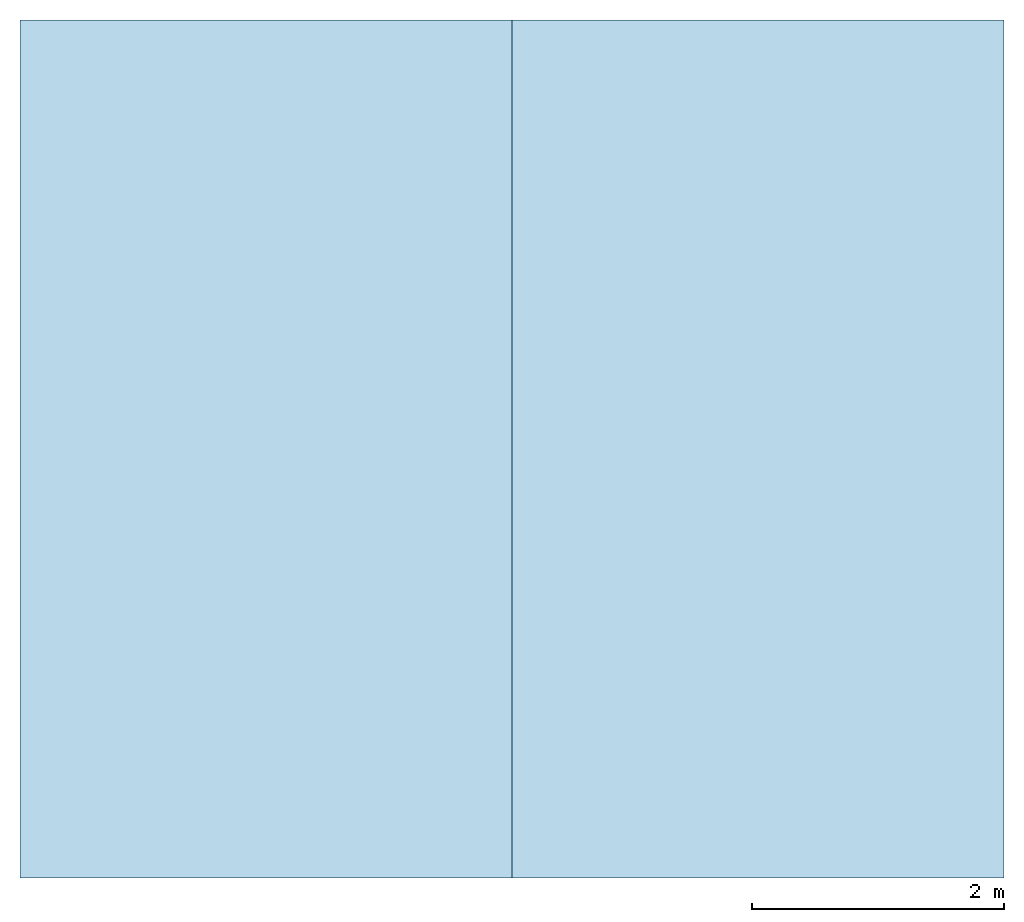
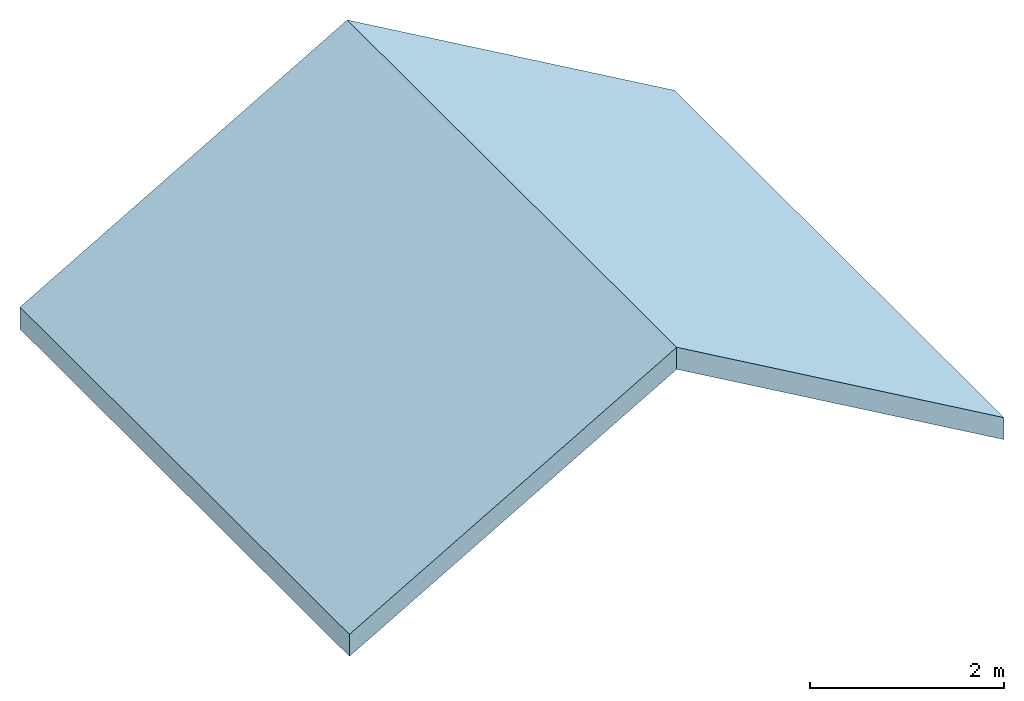
# One storey: 2 slabs, 1 element without a shape of its own.
"""IFC2X3 building model written with IfcOpenShell, lengths in millimetres."""

from ifc_helpers import new_model, entity, si_unit, converted_unit, derived_unit, direction, frame, frame_2d, origin, place, context, subcontext, project, spatial, rectangle, extrude, material, layer, layer_set, element, aggregate, save


model = new_model("IFC2X3")

# Units and contexts
model_context = context("Model", 3, precision=0.01, world=origin(), true_north=direction((6.12303176911189e-17, 1.0)))
body_context = subcontext(model_context, "Body", "Model", "MODEL_VIEW")
ifc_project = project(units=[si_unit("LENGTHUNIT", "METRE", prefix="MILLI"), si_unit("AREAUNIT", "SQUARE_METRE"), si_unit("VOLUMEUNIT", "CUBIC_METRE"), converted_unit("PLANEANGLEUNIT", "DEGREE", entity("IfcRatioMeasure", 0.0174532925199433), si_unit("PLANEANGLEUNIT", "RADIAN"), dimensions=[0, 0, 0, 0, 0, 0, 0]), si_unit("MASSUNIT", "GRAM", prefix="KILO"), si_unit("TIMEUNIT", "SECOND"), si_unit("FREQUENCYUNIT", "HERTZ"), si_unit("THERMODYNAMICTEMPERATUREUNIT", "DEGREE_CELSIUS"), derived_unit("THERMALTRANSMITTANCEUNIT", [(si_unit("MASSUNIT", "GRAM", prefix="KILO"), 1), (si_unit("THERMODYNAMICTEMPERATUREUNIT", "KELVIN"), -1), (si_unit("TIMEUNIT", "SECOND"), -3)]), derived_unit("VOLUMETRICFLOWRATEUNIT", [(si_unit("LENGTHUNIT", "METRE"), 3), (si_unit("TIMEUNIT", "SECOND"), -1)]), si_unit("ELECTRICCURRENTUNIT", "AMPERE"), si_unit("ELECTRICVOLTAGEUNIT", "VOLT"), si_unit("POWERUNIT", "WATT"), si_unit("FORCEUNIT", "NEWTON", prefix="KILO"), si_unit("ILLUMINANCEUNIT", "LUX"), si_unit("LUMINOUSFLUXUNIT", "LUMEN"), si_unit("LUMINOUSINTENSITYUNIT", "CANDELA"), derived_unit("USERDEFINED", [(si_unit("MASSUNIT", "GRAM", prefix="KILO"), -1), (si_unit("LENGTHUNIT", "METRE"), -2), (si_unit("TIMEUNIT", "SECOND"), 3), (si_unit("LUMINOUSFLUXUNIT", "LUMEN"), 1)]), derived_unit("LINEARVELOCITYUNIT", [(si_unit("LENGTHUNIT", "METRE"), 1), (si_unit("TIMEUNIT", "SECOND"), -1)]), si_unit("PRESSUREUNIT", "PASCAL"), derived_unit("USERDEFINED", [(si_unit("LENGTHUNIT", "METRE"), -2), (si_unit("MASSUNIT", "GRAM", prefix="KILO"), 1), (si_unit("TIMEUNIT", "SECOND"), -2)])], contexts=[model_context])

# Site, building, storey
site_placement = place(None, origin())
site = spatial("IfcSite", under=ifc_project, at=site_placement, CompositionType="ELEMENT")
building_placement = place(site_placement, origin())
building = spatial("IfcBuilding", under=site, at=building_placement, CompositionType="ELEMENT")
storey_placement = place(building_placement, frame((0.0, 0.0, 4000.0)))
storey = spatial("IfcBuildingStorey", under=building, at=storey_placement, Name="Level 1", CompositionType="ELEMENT", Elevation=4000.0)

# Roof, slabs
roof_placement = place(storey_placement, frame((-4953.60563367416, -2292.6654969841, 0.0)))
roof = element("IfcRoof", 1, at=roof_placement, inside=storey)
ifc_material_1 = material()
ifc_layer_1 = layer(ifc_material_1, 20.0)
ifc_material_2 = material()
ifc_layer_2 = layer(ifc_material_2, 12.5)
ifc_material_3 = material()
ifc_layer_3 = layer(ifc_material_3, 195.0)
ifc_material_4 = material()
ifc_layer_4 = layer(ifc_material_4, 12.5)
ifc_layer_set = layer_set([ifc_layer_1, ifc_layer_2, ifc_layer_3, ifc_layer_4])
slab_1_placement = place(roof_placement, origin())
slab_1 = element("IfcSlab", 2, at=slab_1_placement, material=ifc_layer_set, PredefinedType="ROOF", context=body_context, shape_type="SweptSolid", body=[
    extrude(rectangle(XDim=4503.33209967908, YDim=6800.0, at=frame_2d((-2.27373675443232e-13, 0.0), x_axis=(-1.0, 0.0))), frame((1950.0, 3400.0, 1125.83302491977), z_axis=(-0.5, 0.0, 0.866025403784439), x_axis=(0.866025403784439, 0.0, 0.5)), (0.5, 0.0, 0.866025403784439), 277.12812921102),
])
slab_2_placement = place(roof_placement, origin())
slab_2 = element("IfcSlab", 3, at=slab_2_placement, material=ifc_layer_set, PredefinedType="ROOF", context=body_context, shape_type="SweptSolid", body=[
    extrude(rectangle(XDim=6800.0, YDim=4503.33209967908, at=frame_2d((-2.27373675443232e-13, 0.0), x_axis=(0.0, -1.0))), frame((5850.0, 3400.0, 1125.83302491977), z_axis=(0.5, 0.0, 0.866025403784439), x_axis=(0.866025403784439, 0.0, -0.5)), (-0.5, 0.0, 0.866025403784439), 277.12812921102),
])
aggregate(roof, [slab_1, slab_2])

save(model, "model.ifc")
